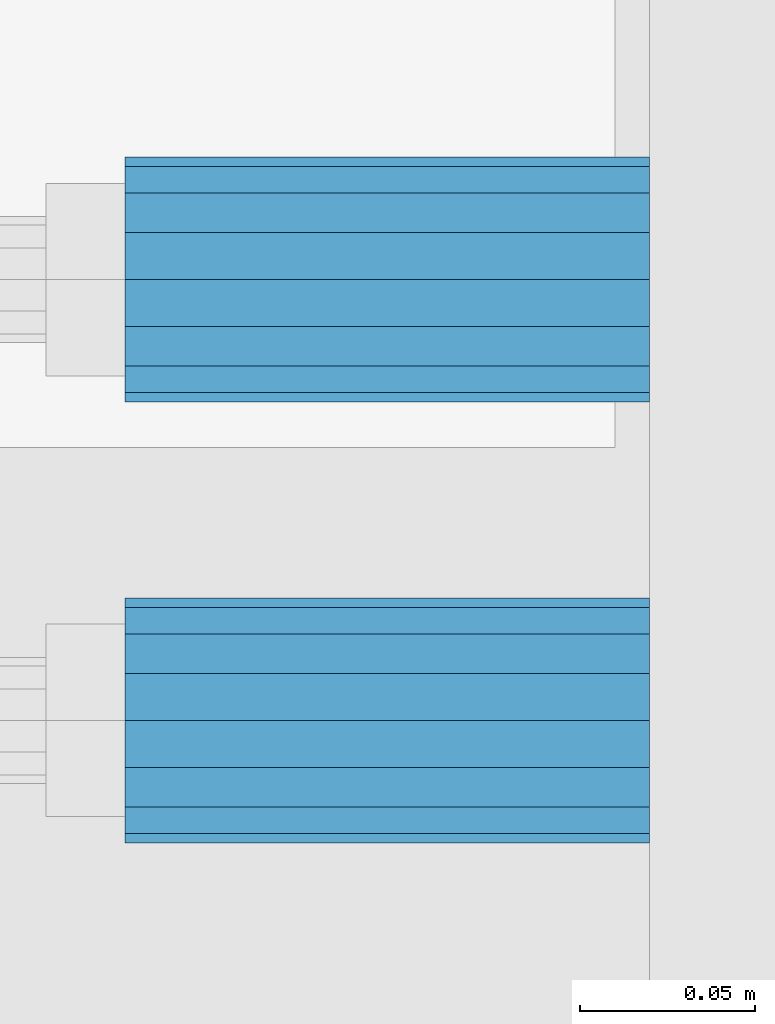
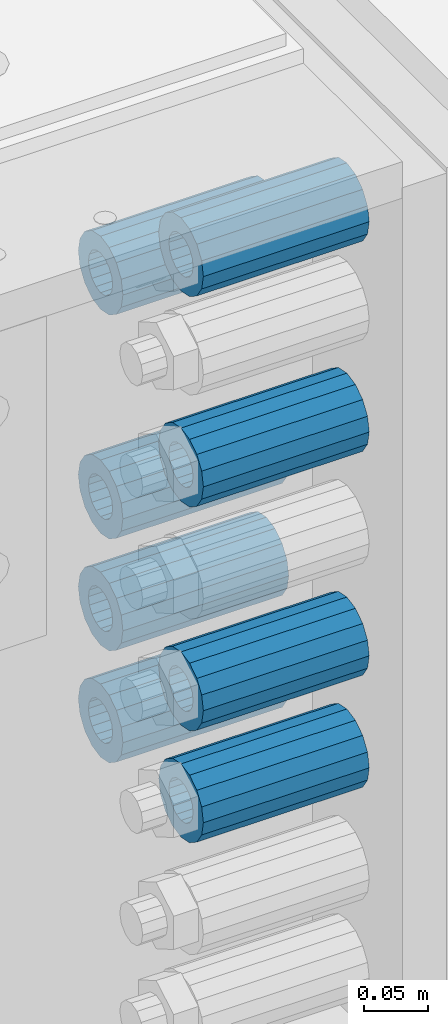
# One storey, part 157 of 242: 8 beams.
"""IFC2X3 building model written with IfcOpenShell, lengths in millimetres."""

from ifc_helpers import new_model, si_unit, frame, origin_with_axes, place, context, subcontext, project, spatial, faceted_brep, material, type_object, element, save


model = new_model("IFC2X3")

# Units and contexts
model_context = context("Model", 3, precision=1e-05, world=origin_with_axes())
body_context = subcontext(model_context, "Body", "Model", "MODEL_VIEW")
ifc_project = project(units=[si_unit("LENGTHUNIT", "METRE", prefix="MILLI"), si_unit("AREAUNIT", "SQUARE_METRE"), si_unit("VOLUMEUNIT", "CUBIC_METRE"), si_unit("MASSUNIT", "GRAM", prefix="KILO"), si_unit("TIMEUNIT", "SECOND"), si_unit("PLANEANGLEUNIT", "RADIAN"), si_unit("SOLIDANGLEUNIT", "STERADIAN"), si_unit("THERMODYNAMICTEMPERATUREUNIT", "DEGREE_CELSIUS"), si_unit("LUMINOUSINTENSITYUNIT", "LUMEN")], contexts=[model_context])

# Site, building, storey
site_placement = place(None, origin_with_axes())
site = spatial("IfcSite", under=ifc_project, at=site_placement, CompositionType="ELEMENT")
building_placement = place(site_placement, origin_with_axes())
building = spatial("IfcBuilding", under=site, at=building_placement, Name="Standard", CompositionType="ELEMENT")
storey_placement = place(building_placement, origin_with_axes())
storey = spatial("IfcBuildingStorey", under=building, at=storey_placement, Name="Undefined", CompositionType="ELEMENT", Elevation=0.0)

# Beams
ifc_material = material()
beam_type = type_object("IfcBeamType", PredefinedType="NOTDEFINED")
beam_1_placement = place(storey_placement, frame((-22210.0, -23937.0, -504.0), z_axis=(0.0, 0.0, 1.0), x_axis=(1.0, 0.0, 0.0)))
element("IfcBeam", 1, at=beam_1_placement, inside=storey, type_object=beam_type, material=ifc_material, context=body_context, shape_type="Brep", body=[
    faceted_brep([(1.33248249767348e-07, -19.0000000004493, -6.26823748461902e-09), (0.0, -17.5537111177146, 7.27098521493673), (150.0, -17.5537111177146, 7.27098521493673), (150.0, -19.0, 0.0), (0.0, -13.4350288425449, 13.4350288425444), (150.0, -13.4350288425449, 13.4350288425444), (0.0, -7.27098521493826, 17.5537111177144), (150.0, -7.27098521493826, 17.5537111177144), (-6.29370333626866e-09, -4.49290382675827e-10, 18.9999999937318), (150.0, 0.0, 19.0), (0.0, 7.27098521493826, 17.5537111177144), (150.0, 7.27098521493826, 17.5537111177144), (0.0, 13.4350288425449, 13.4350288425444), (150.0, 13.4350288425449, 13.4350288425444), (0.0, 17.5537111177146, 7.2709852149367), (150.0, 17.5537111177146, 7.2709852149367), (-1.31243723444641e-07, 18.9999999995507, -6.26823748461902e-09), (150.0, 19.0, 0.0), (0.0, 17.5537111177146, -7.2709852149367), (150.0, 17.5537111177146, -7.2709852149367), (0.0, 13.4350288425449, -13.4350288425444), (150.0, 13.4350288425449, -13.4350288425444), (0.0, 7.27098521493826, -17.5537111177144), (150.0, 7.27098521493826, -17.5537111177144), (8.2982296589762e-09, -4.49290382675827e-10, -19.0000000062719), (150.0, 0.0, -19.0), (0.0, -7.27098521493826, -17.5537111177144), (150.0, -7.27098521493826, -17.5537111177144), (0.0, -13.4350288425449, -13.4350288425444), (150.0, -13.4350288425449, -13.4350288425444), (0.0, -17.5537111177146, -7.2709852149367), (150.0, -17.5537111177146, -7.2709852149367), (-3.63797880709171e-12, -35.0, 0.0), (-3.63797880709171e-12, -32.335783637895, -13.3939201327812), (150.0, -32.3357836378964, -13.3939201327782), (150.0, -35.0, 0.0), (0.0, -24.7487373415292, -24.7487373415315), (150.0, -24.7487373415279, -24.7487373415292), (0.0, -13.3939201327782, -32.3357836378964), (150.0, -13.3939201327776, -32.335783637895), (0.0, 0.0, -35.0000000000036), (150.0, 0.0, -35.0), (0.0, 13.3939201327782, -32.3357836378964), (150.0, 13.3939201327776, -32.335783637895), (0.0, 24.7487373415292, -24.7487373415315), (150.0, 24.7487373415279, -24.7487373415292), (-3.63797880709171e-12, 32.335783637895, -13.3939201327812), (150.0, 32.3357836378964, -13.3939201327781), (-3.63797880709171e-12, 35.0, 0.0), (150.0, 35.0, 0.0), (-7.27595761418343e-12, 32.335783637895, 13.3939201327739), (150.0, 32.3357836378964, 13.3939201327781), (-7.27595761418343e-12, 24.7487373415292, 24.7487373415242), (150.0, 24.7487373415279, 24.7487373415292), (-7.27595761418343e-12, 13.3939201327781, 32.3357836378891), (150.0, 13.3939201327776, 32.335783637895), (-1.09139364212751e-11, 0.0, 34.9999999999964), (150.0, 0.0, 35.0), (-7.27595761418343e-12, -13.3939201327781, 32.3357836378891), (150.0, -13.3939201327776, 32.335783637895), (-7.27595761418343e-12, -24.7487373415292, 24.7487373415242), (150.0, -24.7487373415279, 24.7487373415292), (-7.27595761418343e-12, -32.335783637895, 13.3939201327739), (150.0, -32.3357836378964, 13.3939201327781)], [[[0, 1, 2, 3]], [[1, 4, 5, 2]], [[4, 6, 7, 5]], [[6, 8, 9, 7]], [[8, 10, 11, 9]], [[10, 12, 13, 11]], [[12, 14, 15, 13]], [[14, 16, 17, 15]], [[16, 18, 19, 17]], [[18, 20, 21, 19]], [[20, 22, 23, 21]], [[22, 24, 25, 23]], [[24, 26, 27, 25]], [[26, 28, 29, 27]], [[28, 30, 31, 29]], [[30, 0, 3, 31]], [[32, 33, 34, 35]], [[33, 36, 37, 34]], [[36, 38, 39, 37]], [[38, 40, 41, 39]], [[40, 42, 43, 41]], [[42, 44, 45, 43]], [[44, 46, 47, 45]], [[46, 48, 49, 47]], [[48, 50, 51, 49]], [[50, 52, 53, 51]], [[52, 54, 55, 53]], [[54, 56, 57, 55]], [[56, 58, 59, 57]], [[58, 60, 61, 59]], [[60, 62, 63, 61]], [[62, 32, 35, 63]], [[37, 39, 41, 43, 45, 47, 49, 51, 53, 55, 57, 59, 61, 63, 35, 34], [5, 7, 9, 11, 13, 15, 17, 19, 21, 23, 25, 27, 29, 31, 3, 2]], [[62, 60, 58, 56, 54, 52, 50, 48, 46, 44, 42, 40, 38, 36, 33, 32], [30, 28, 26, 24, 22, 20, 18, 16, 14, 12, 10, 8, 6, 4, 1, 0]]]),
])
beam_2_placement = place(storey_placement, frame((-22210.0, -23937.0, -611.0), z_axis=(0.0, 0.0, 1.0), x_axis=(1.0, 0.0, 0.0)))
element("IfcBeam", 2, at=beam_2_placement, inside=storey, type_object=beam_type, material=ifc_material, context=body_context, shape_type="Brep", body=[
    faceted_brep([(1.33248249767348e-07, -19.0000000004493, -6.26823748461902e-09), (0.0, -17.5537111177146, 7.27098521493673), (150.0, -17.5537111177146, 7.27098521493673), (150.0, -19.0, 0.0), (0.0, -13.4350288425449, 13.4350288425444), (150.0, -13.4350288425449, 13.4350288425444), (0.0, -7.27098521493826, 17.5537111177144), (150.0, -7.27098521493826, 17.5537111177144), (-6.29370333626866e-09, -4.49290382675827e-10, 18.9999999937318), (150.0, 0.0, 19.0), (0.0, 7.27098521493826, 17.5537111177144), (150.0, 7.27098521493826, 17.5537111177144), (0.0, 13.4350288425449, 13.4350288425444), (150.0, 13.4350288425449, 13.4350288425444), (0.0, 17.5537111177146, 7.2709852149367), (150.0, 17.5537111177146, 7.2709852149367), (-1.31243723444641e-07, 18.9999999995507, -6.26823748461902e-09), (150.0, 19.0, 0.0), (0.0, 17.5537111177146, -7.2709852149367), (150.0, 17.5537111177146, -7.2709852149367), (0.0, 13.4350288425449, -13.4350288425444), (150.0, 13.4350288425449, -13.4350288425444), (0.0, 7.27098521493826, -17.5537111177144), (150.0, 7.27098521493826, -17.5537111177144), (8.2982296589762e-09, -4.49290382675827e-10, -19.0000000062719), (150.0, 0.0, -19.0), (0.0, -7.27098521493826, -17.5537111177144), (150.0, -7.27098521493826, -17.5537111177144), (0.0, -13.4350288425449, -13.4350288425444), (150.0, -13.4350288425449, -13.4350288425444), (0.0, -17.5537111177146, -7.2709852149367), (150.0, -17.5537111177146, -7.2709852149367), (-3.63797880709171e-12, -35.0, 0.0), (-3.63797880709171e-12, -32.335783637895, -13.3939201327812), (150.0, -32.3357836378964, -13.3939201327782), (150.0, -35.0, 0.0), (0.0, -24.7487373415292, -24.7487373415315), (150.0, -24.7487373415279, -24.7487373415292), (0.0, -13.3939201327782, -32.3357836378964), (150.0, -13.3939201327776, -32.335783637895), (0.0, 0.0, -35.0000000000036), (150.0, 0.0, -35.0), (0.0, 13.3939201327782, -32.3357836378964), (150.0, 13.3939201327776, -32.335783637895), (0.0, 24.7487373415292, -24.7487373415315), (150.0, 24.7487373415279, -24.7487373415292), (-3.63797880709171e-12, 32.335783637895, -13.3939201327812), (150.0, 32.3357836378964, -13.3939201327781), (-3.63797880709171e-12, 35.0, 0.0), (150.0, 35.0, 0.0), (-7.27595761418343e-12, 32.335783637895, 13.3939201327739), (150.0, 32.3357836378964, 13.3939201327781), (-7.27595761418343e-12, 24.7487373415292, 24.7487373415242), (150.0, 24.7487373415279, 24.7487373415292), (-7.27595761418343e-12, 13.3939201327781, 32.3357836378891), (150.0, 13.3939201327776, 32.335783637895), (-1.09139364212751e-11, 0.0, 34.9999999999964), (150.0, 0.0, 35.0), (-7.27595761418343e-12, -13.3939201327781, 32.3357836378891), (150.0, -13.3939201327776, 32.335783637895), (-7.27595761418343e-12, -24.7487373415292, 24.7487373415242), (150.0, -24.7487373415279, 24.7487373415292), (-7.27595761418343e-12, -32.335783637895, 13.3939201327739), (150.0, -32.3357836378964, 13.3939201327781)], [[[0, 1, 2, 3]], [[1, 4, 5, 2]], [[4, 6, 7, 5]], [[6, 8, 9, 7]], [[8, 10, 11, 9]], [[10, 12, 13, 11]], [[12, 14, 15, 13]], [[14, 16, 17, 15]], [[16, 18, 19, 17]], [[18, 20, 21, 19]], [[20, 22, 23, 21]], [[22, 24, 25, 23]], [[24, 26, 27, 25]], [[26, 28, 29, 27]], [[28, 30, 31, 29]], [[30, 0, 3, 31]], [[32, 33, 34, 35]], [[33, 36, 37, 34]], [[36, 38, 39, 37]], [[38, 40, 41, 39]], [[40, 42, 43, 41]], [[42, 44, 45, 43]], [[44, 46, 47, 45]], [[46, 48, 49, 47]], [[48, 50, 51, 49]], [[50, 52, 53, 51]], [[52, 54, 55, 53]], [[54, 56, 57, 55]], [[56, 58, 59, 57]], [[58, 60, 61, 59]], [[60, 62, 63, 61]], [[62, 32, 35, 63]], [[37, 39, 41, 43, 45, 47, 49, 51, 53, 55, 57, 59, 61, 63, 35, 34], [5, 7, 9, 11, 13, 15, 17, 19, 21, 23, 25, 27, 29, 31, 3, 2]], [[62, 60, 58, 56, 54, 52, 50, 48, 46, 44, 42, 40, 38, 36, 33, 32], [30, 28, 26, 24, 22, 20, 18, 16, 14, 12, 10, 8, 6, 4, 1, 0]]]),
])
beam_3_placement = place(storey_placement, frame((-22210.0, -24063.0, -290.0), z_axis=(0.0, 0.0, 1.0), x_axis=(1.0, 0.0, 0.0)))
element("IfcBeam", 3, at=beam_3_placement, inside=storey, type_object=beam_type, material=ifc_material, context=body_context, shape_type="Brep", body=[
    faceted_brep([(1.33248249767348e-07, -19.0000000004493, -6.26823748461902e-09), (0.0, -17.5537111177146, 7.27098521493673), (150.0, -17.5537111177146, 7.27098521493673), (150.0, -19.0, 0.0), (0.0, -13.4350288425449, 13.4350288425444), (150.0, -13.4350288425449, 13.4350288425444), (0.0, -7.27098521493826, 17.5537111177144), (150.0, -7.27098521493826, 17.5537111177144), (-6.29370333626866e-09, -4.49290382675827e-10, 18.9999999937318), (150.0, 0.0, 19.0), (0.0, 7.27098521493826, 17.5537111177144), (150.0, 7.27098521493826, 17.5537111177144), (0.0, 13.4350288425449, 13.4350288425444), (150.0, 13.4350288425449, 13.4350288425444), (0.0, 17.5537111177146, 7.2709852149367), (150.0, 17.5537111177146, 7.2709852149367), (-1.31243723444641e-07, 18.9999999995507, -6.26823748461902e-09), (150.0, 19.0, 0.0), (0.0, 17.5537111177146, -7.2709852149367), (150.0, 17.5537111177146, -7.2709852149367), (0.0, 13.4350288425449, -13.4350288425444), (150.0, 13.4350288425449, -13.4350288425444), (0.0, 7.27098521493826, -17.5537111177144), (150.0, 7.27098521493826, -17.5537111177144), (8.2982296589762e-09, -4.49290382675827e-10, -19.0000000062719), (150.0, 0.0, -19.0), (0.0, -7.27098521493826, -17.5537111177144), (150.0, -7.27098521493826, -17.5537111177144), (0.0, -13.4350288425449, -13.4350288425444), (150.0, -13.4350288425449, -13.4350288425444), (0.0, -17.5537111177146, -7.2709852149367), (150.0, -17.5537111177146, -7.2709852149367), (-3.63797880709171e-12, -35.0, 0.0), (-3.63797880709171e-12, -32.335783637895, -13.3939201327812), (150.0, -32.3357836378964, -13.3939201327782), (150.0, -35.0, 0.0), (0.0, -24.7487373415292, -24.7487373415315), (150.0, -24.7487373415279, -24.7487373415292), (0.0, -13.3939201327782, -32.3357836378964), (150.0, -13.3939201327776, -32.335783637895), (0.0, 0.0, -35.0000000000036), (150.0, 0.0, -35.0), (0.0, 13.3939201327782, -32.3357836378964), (150.0, 13.3939201327776, -32.335783637895), (0.0, 24.7487373415292, -24.7487373415315), (150.0, 24.7487373415279, -24.7487373415292), (-3.63797880709171e-12, 32.335783637895, -13.3939201327812), (150.0, 32.3357836378964, -13.3939201327781), (-3.63797880709171e-12, 35.0, 0.0), (150.0, 35.0, 0.0), (-7.27595761418343e-12, 32.335783637895, 13.3939201327739), (150.0, 32.3357836378964, 13.3939201327781), (-7.27595761418343e-12, 24.7487373415292, 24.7487373415242), (150.0, 24.7487373415279, 24.7487373415292), (-7.27595761418343e-12, 13.3939201327781, 32.3357836378891), (150.0, 13.3939201327776, 32.335783637895), (-1.09139364212751e-11, 0.0, 34.9999999999964), (150.0, 0.0, 35.0), (-7.27595761418343e-12, -13.3939201327781, 32.3357836378891), (150.0, -13.3939201327776, 32.335783637895), (-7.27595761418343e-12, -24.7487373415292, 24.7487373415242), (150.0, -24.7487373415279, 24.7487373415292), (-7.27595761418343e-12, -32.335783637895, 13.3939201327739), (150.0, -32.3357836378964, 13.3939201327781)], [[[0, 1, 2, 3]], [[1, 4, 5, 2]], [[4, 6, 7, 5]], [[6, 8, 9, 7]], [[8, 10, 11, 9]], [[10, 12, 13, 11]], [[12, 14, 15, 13]], [[14, 16, 17, 15]], [[16, 18, 19, 17]], [[18, 20, 21, 19]], [[20, 22, 23, 21]], [[22, 24, 25, 23]], [[24, 26, 27, 25]], [[26, 28, 29, 27]], [[28, 30, 31, 29]], [[30, 0, 3, 31]], [[32, 33, 34, 35]], [[33, 36, 37, 34]], [[36, 38, 39, 37]], [[38, 40, 41, 39]], [[40, 42, 43, 41]], [[42, 44, 45, 43]], [[44, 46, 47, 45]], [[46, 48, 49, 47]], [[48, 50, 51, 49]], [[50, 52, 53, 51]], [[52, 54, 55, 53]], [[54, 56, 57, 55]], [[56, 58, 59, 57]], [[58, 60, 61, 59]], [[60, 62, 63, 61]], [[62, 32, 35, 63]], [[37, 39, 41, 43, 45, 47, 49, 51, 53, 55, 57, 59, 61, 63, 35, 34], [5, 7, 9, 11, 13, 15, 17, 19, 21, 23, 25, 27, 29, 31, 3, 2]], [[62, 60, 58, 56, 54, 52, 50, 48, 46, 44, 42, 40, 38, 36, 33, 32], [30, 28, 26, 24, 22, 20, 18, 16, 14, 12, 10, 8, 6, 4, 1, 0]]]),
])
beam_4_placement = place(storey_placement, frame((-22210.0, -23937.0, -183.0), z_axis=(0.0, 0.0, 1.0), x_axis=(1.0, 0.0, 0.0)))
element("IfcBeam", 4, at=beam_4_placement, inside=storey, type_object=beam_type, material=ifc_material, context=body_context, shape_type="Brep", body=[
    faceted_brep([(1.33248249767348e-07, -19.0000000004493, -6.26823748461902e-09), (0.0, -17.5537111177146, 7.27098521493673), (150.0, -17.5537111177146, 7.27098521493673), (150.0, -19.0, 0.0), (0.0, -13.4350288425449, 13.4350288425444), (150.0, -13.4350288425449, 13.4350288425444), (0.0, -7.27098521493826, 17.5537111177144), (150.0, -7.27098521493826, 17.5537111177144), (-6.29370333626866e-09, -4.49290382675827e-10, 18.9999999937318), (150.0, 0.0, 19.0), (0.0, 7.27098521493826, 17.5537111177144), (150.0, 7.27098521493826, 17.5537111177144), (0.0, 13.4350288425449, 13.4350288425444), (150.0, 13.4350288425449, 13.4350288425444), (0.0, 17.5537111177146, 7.2709852149367), (150.0, 17.5537111177146, 7.2709852149367), (-1.31243723444641e-07, 18.9999999995507, -6.26823748461902e-09), (150.0, 19.0, 0.0), (0.0, 17.5537111177146, -7.2709852149367), (150.0, 17.5537111177146, -7.2709852149367), (0.0, 13.4350288425449, -13.4350288425444), (150.0, 13.4350288425449, -13.4350288425444), (0.0, 7.27098521493826, -17.5537111177144), (150.0, 7.27098521493826, -17.5537111177144), (8.2982296589762e-09, -4.49290382675827e-10, -19.0000000062719), (150.0, 0.0, -19.0), (0.0, -7.27098521493826, -17.5537111177144), (150.0, -7.27098521493826, -17.5537111177144), (0.0, -13.4350288425449, -13.4350288425444), (150.0, -13.4350288425449, -13.4350288425444), (0.0, -17.5537111177146, -7.2709852149367), (150.0, -17.5537111177146, -7.2709852149367), (-3.63797880709171e-12, -35.0, 0.0), (-3.63797880709171e-12, -32.335783637895, -13.3939201327812), (150.0, -32.3357836378964, -13.3939201327782), (150.0, -35.0, 0.0), (0.0, -24.7487373415292, -24.7487373415315), (150.0, -24.7487373415279, -24.7487373415292), (0.0, -13.3939201327782, -32.3357836378964), (150.0, -13.3939201327776, -32.335783637895), (0.0, 0.0, -35.0000000000036), (150.0, 0.0, -35.0), (0.0, 13.3939201327782, -32.3357836378964), (150.0, 13.3939201327776, -32.335783637895), (0.0, 24.7487373415292, -24.7487373415315), (150.0, 24.7487373415279, -24.7487373415292), (-3.63797880709171e-12, 32.335783637895, -13.3939201327812), (150.0, 32.3357836378964, -13.3939201327781), (-3.63797880709171e-12, 35.0, 0.0), (150.0, 35.0, 0.0), (-7.27595761418343e-12, 32.335783637895, 13.3939201327739), (150.0, 32.3357836378964, 13.3939201327781), (-7.27595761418343e-12, 24.7487373415292, 24.7487373415242), (150.0, 24.7487373415279, 24.7487373415292), (-7.27595761418343e-12, 13.3939201327781, 32.3357836378891), (150.0, 13.3939201327776, 32.335783637895), (-1.09139364212751e-11, 0.0, 34.9999999999964), (150.0, 0.0, 35.0), (-7.27595761418343e-12, -13.3939201327781, 32.3357836378891), (150.0, -13.3939201327776, 32.335783637895), (-7.27595761418343e-12, -24.7487373415292, 24.7487373415242), (150.0, -24.7487373415279, 24.7487373415292), (-7.27595761418343e-12, -32.335783637895, 13.3939201327739), (150.0, -32.3357836378964, 13.3939201327781)], [[[0, 1, 2, 3]], [[1, 4, 5, 2]], [[4, 6, 7, 5]], [[6, 8, 9, 7]], [[8, 10, 11, 9]], [[10, 12, 13, 11]], [[12, 14, 15, 13]], [[14, 16, 17, 15]], [[16, 18, 19, 17]], [[18, 20, 21, 19]], [[20, 22, 23, 21]], [[22, 24, 25, 23]], [[24, 26, 27, 25]], [[26, 28, 29, 27]], [[28, 30, 31, 29]], [[30, 0, 3, 31]], [[32, 33, 34, 35]], [[33, 36, 37, 34]], [[36, 38, 39, 37]], [[38, 40, 41, 39]], [[40, 42, 43, 41]], [[42, 44, 45, 43]], [[44, 46, 47, 45]], [[46, 48, 49, 47]], [[48, 50, 51, 49]], [[50, 52, 53, 51]], [[52, 54, 55, 53]], [[54, 56, 57, 55]], [[56, 58, 59, 57]], [[58, 60, 61, 59]], [[60, 62, 63, 61]], [[62, 32, 35, 63]], [[37, 39, 41, 43, 45, 47, 49, 51, 53, 55, 57, 59, 61, 63, 35, 34], [5, 7, 9, 11, 13, 15, 17, 19, 21, 23, 25, 27, 29, 31, 3, 2]], [[62, 60, 58, 56, 54, 52, 50, 48, 46, 44, 42, 40, 38, 36, 33, 32], [30, 28, 26, 24, 22, 20, 18, 16, 14, 12, 10, 8, 6, 4, 1, 0]]]),
])
beam_5_placement = place(storey_placement, frame((-22210.0, -24063.0, -504.0), z_axis=(0.0, 0.0, 1.0), x_axis=(1.0, 0.0, 0.0)))
element("IfcBeam", 5, at=beam_5_placement, inside=storey, type_object=beam_type, material=ifc_material, context=body_context, shape_type="Brep", body=[
    faceted_brep([(1.33248249767348e-07, -19.0000000004493, -6.26823748461902e-09), (0.0, -17.5537111177146, 7.27098521493673), (150.0, -17.5537111177146, 7.27098521493673), (150.0, -19.0, 0.0), (0.0, -13.4350288425449, 13.4350288425444), (150.0, -13.4350288425449, 13.4350288425444), (0.0, -7.27098521493826, 17.5537111177144), (150.0, -7.27098521493826, 17.5537111177144), (-6.29370333626866e-09, -4.49290382675827e-10, 18.9999999937318), (150.0, 0.0, 19.0), (0.0, 7.27098521493826, 17.5537111177144), (150.0, 7.27098521493826, 17.5537111177144), (0.0, 13.4350288425449, 13.4350288425444), (150.0, 13.4350288425449, 13.4350288425444), (0.0, 17.5537111177146, 7.2709852149367), (150.0, 17.5537111177146, 7.2709852149367), (-1.31243723444641e-07, 18.9999999995507, -6.26823748461902e-09), (150.0, 19.0, 0.0), (0.0, 17.5537111177146, -7.2709852149367), (150.0, 17.5537111177146, -7.2709852149367), (0.0, 13.4350288425449, -13.4350288425444), (150.0, 13.4350288425449, -13.4350288425444), (0.0, 7.27098521493826, -17.5537111177144), (150.0, 7.27098521493826, -17.5537111177144), (8.2982296589762e-09, -4.49290382675827e-10, -19.0000000062719), (150.0, 0.0, -19.0), (0.0, -7.27098521493826, -17.5537111177144), (150.0, -7.27098521493826, -17.5537111177144), (0.0, -13.4350288425449, -13.4350288425444), (150.0, -13.4350288425449, -13.4350288425444), (0.0, -17.5537111177146, -7.2709852149367), (150.0, -17.5537111177146, -7.2709852149367), (-3.63797880709171e-12, -35.0, 0.0), (-3.63797880709171e-12, -32.335783637895, -13.3939201327812), (150.0, -32.3357836378964, -13.3939201327782), (150.0, -35.0, 0.0), (0.0, -24.7487373415292, -24.7487373415315), (150.0, -24.7487373415279, -24.7487373415292), (0.0, -13.3939201327782, -32.3357836378964), (150.0, -13.3939201327776, -32.335783637895), (0.0, 0.0, -35.0000000000036), (150.0, 0.0, -35.0), (0.0, 13.3939201327782, -32.3357836378964), (150.0, 13.3939201327776, -32.335783637895), (0.0, 24.7487373415292, -24.7487373415315), (150.0, 24.7487373415279, -24.7487373415292), (-3.63797880709171e-12, 32.335783637895, -13.3939201327812), (150.0, 32.3357836378964, -13.3939201327781), (-3.63797880709171e-12, 35.0, 0.0), (150.0, 35.0, 0.0), (-7.27595761418343e-12, 32.335783637895, 13.3939201327739), (150.0, 32.3357836378964, 13.3939201327781), (-7.27595761418343e-12, 24.7487373415292, 24.7487373415242), (150.0, 24.7487373415279, 24.7487373415292), (-7.27595761418343e-12, 13.3939201327781, 32.3357836378891), (150.0, 13.3939201327776, 32.335783637895), (-1.09139364212751e-11, 0.0, 34.9999999999964), (150.0, 0.0, 35.0), (-7.27595761418343e-12, -13.3939201327781, 32.3357836378891), (150.0, -13.3939201327776, 32.335783637895), (-7.27595761418343e-12, -24.7487373415292, 24.7487373415242), (150.0, -24.7487373415279, 24.7487373415292), (-7.27595761418343e-12, -32.335783637895, 13.3939201327739), (150.0, -32.3357836378964, 13.3939201327781)], [[[0, 1, 2, 3]], [[1, 4, 5, 2]], [[4, 6, 7, 5]], [[6, 8, 9, 7]], [[8, 10, 11, 9]], [[10, 12, 13, 11]], [[12, 14, 15, 13]], [[14, 16, 17, 15]], [[16, 18, 19, 17]], [[18, 20, 21, 19]], [[20, 22, 23, 21]], [[22, 24, 25, 23]], [[24, 26, 27, 25]], [[26, 28, 29, 27]], [[28, 30, 31, 29]], [[30, 0, 3, 31]], [[32, 33, 34, 35]], [[33, 36, 37, 34]], [[36, 38, 39, 37]], [[38, 40, 41, 39]], [[40, 42, 43, 41]], [[42, 44, 45, 43]], [[44, 46, 47, 45]], [[46, 48, 49, 47]], [[48, 50, 51, 49]], [[50, 52, 53, 51]], [[52, 54, 55, 53]], [[54, 56, 57, 55]], [[56, 58, 59, 57]], [[58, 60, 61, 59]], [[60, 62, 63, 61]], [[62, 32, 35, 63]], [[37, 39, 41, 43, 45, 47, 49, 51, 53, 55, 57, 59, 61, 63, 35, 34], [5, 7, 9, 11, 13, 15, 17, 19, 21, 23, 25, 27, 29, 31, 3, 2]], [[62, 60, 58, 56, 54, 52, 50, 48, 46, 44, 42, 40, 38, 36, 33, 32], [30, 28, 26, 24, 22, 20, 18, 16, 14, 12, 10, 8, 6, 4, 1, 0]]]),
])
beam_6_placement = place(storey_placement, frame((-22210.0, -24063.0, -611.0), z_axis=(0.0, 0.0, 1.0), x_axis=(1.0, 0.0, 0.0)))
element("IfcBeam", 6, at=beam_6_placement, inside=storey, type_object=beam_type, material=ifc_material, context=body_context, shape_type="Brep", body=[
    faceted_brep([(1.33248249767348e-07, -19.0000000004493, -6.26823748461902e-09), (0.0, -17.5537111177146, 7.27098521493673), (150.0, -17.5537111177146, 7.27098521493673), (150.0, -19.0, 0.0), (0.0, -13.4350288425449, 13.4350288425444), (150.0, -13.4350288425449, 13.4350288425444), (0.0, -7.27098521493826, 17.5537111177144), (150.0, -7.27098521493826, 17.5537111177144), (-6.29370333626866e-09, -4.49290382675827e-10, 18.9999999937318), (150.0, 0.0, 19.0), (0.0, 7.27098521493826, 17.5537111177144), (150.0, 7.27098521493826, 17.5537111177144), (0.0, 13.4350288425449, 13.4350288425444), (150.0, 13.4350288425449, 13.4350288425444), (0.0, 17.5537111177146, 7.2709852149367), (150.0, 17.5537111177146, 7.2709852149367), (-1.31243723444641e-07, 18.9999999995507, -6.26823748461902e-09), (150.0, 19.0, 0.0), (0.0, 17.5537111177146, -7.2709852149367), (150.0, 17.5537111177146, -7.2709852149367), (0.0, 13.4350288425449, -13.4350288425444), (150.0, 13.4350288425449, -13.4350288425444), (0.0, 7.27098521493826, -17.5537111177144), (150.0, 7.27098521493826, -17.5537111177144), (8.2982296589762e-09, -4.49290382675827e-10, -19.0000000062719), (150.0, 0.0, -19.0), (0.0, -7.27098521493826, -17.5537111177144), (150.0, -7.27098521493826, -17.5537111177144), (0.0, -13.4350288425449, -13.4350288425444), (150.0, -13.4350288425449, -13.4350288425444), (0.0, -17.5537111177146, -7.2709852149367), (150.0, -17.5537111177146, -7.2709852149367), (-3.63797880709171e-12, -35.0, 0.0), (-3.63797880709171e-12, -32.335783637895, -13.3939201327812), (150.0, -32.3357836378964, -13.3939201327782), (150.0, -35.0, 0.0), (0.0, -24.7487373415292, -24.7487373415315), (150.0, -24.7487373415279, -24.7487373415292), (0.0, -13.3939201327782, -32.3357836378964), (150.0, -13.3939201327776, -32.335783637895), (0.0, 0.0, -35.0000000000036), (150.0, 0.0, -35.0), (0.0, 13.3939201327782, -32.3357836378964), (150.0, 13.3939201327776, -32.335783637895), (0.0, 24.7487373415292, -24.7487373415315), (150.0, 24.7487373415279, -24.7487373415292), (-3.63797880709171e-12, 32.335783637895, -13.3939201327812), (150.0, 32.3357836378964, -13.3939201327781), (-3.63797880709171e-12, 35.0, 0.0), (150.0, 35.0, 0.0), (-7.27595761418343e-12, 32.335783637895, 13.3939201327739), (150.0, 32.3357836378964, 13.3939201327781), (-7.27595761418343e-12, 24.7487373415292, 24.7487373415242), (150.0, 24.7487373415279, 24.7487373415292), (-7.27595761418343e-12, 13.3939201327781, 32.3357836378891), (150.0, 13.3939201327776, 32.335783637895), (-1.09139364212751e-11, 0.0, 34.9999999999964), (150.0, 0.0, 35.0), (-7.27595761418343e-12, -13.3939201327781, 32.3357836378891), (150.0, -13.3939201327776, 32.335783637895), (-7.27595761418343e-12, -24.7487373415292, 24.7487373415242), (150.0, -24.7487373415279, 24.7487373415292), (-7.27595761418343e-12, -32.335783637895, 13.3939201327739), (150.0, -32.3357836378964, 13.3939201327781)], [[[0, 1, 2, 3]], [[1, 4, 5, 2]], [[4, 6, 7, 5]], [[6, 8, 9, 7]], [[8, 10, 11, 9]], [[10, 12, 13, 11]], [[12, 14, 15, 13]], [[14, 16, 17, 15]], [[16, 18, 19, 17]], [[18, 20, 21, 19]], [[20, 22, 23, 21]], [[22, 24, 25, 23]], [[24, 26, 27, 25]], [[26, 28, 29, 27]], [[28, 30, 31, 29]], [[30, 0, 3, 31]], [[32, 33, 34, 35]], [[33, 36, 37, 34]], [[36, 38, 39, 37]], [[38, 40, 41, 39]], [[40, 42, 43, 41]], [[42, 44, 45, 43]], [[44, 46, 47, 45]], [[46, 48, 49, 47]], [[48, 50, 51, 49]], [[50, 52, 53, 51]], [[52, 54, 55, 53]], [[54, 56, 57, 55]], [[56, 58, 59, 57]], [[58, 60, 61, 59]], [[60, 62, 63, 61]], [[62, 32, 35, 63]], [[37, 39, 41, 43, 45, 47, 49, 51, 53, 55, 57, 59, 61, 63, 35, 34], [5, 7, 9, 11, 13, 15, 17, 19, 21, 23, 25, 27, 29, 31, 3, 2]], [[62, 60, 58, 56, 54, 52, 50, 48, 46, 44, 42, 40, 38, 36, 33, 32], [30, 28, 26, 24, 22, 20, 18, 16, 14, 12, 10, 8, 6, 4, 1, 0]]]),
])
beam_7_placement = place(storey_placement, frame((-22210.0, -23937.0, -397.0), z_axis=(0.0, 0.0, 1.0), x_axis=(1.0, 0.0, 0.0)))
element("IfcBeam", 7, at=beam_7_placement, inside=storey, type_object=beam_type, material=ifc_material, context=body_context, shape_type="Brep", body=[
    faceted_brep([(1.33248249767348e-07, -19.0000000004493, -6.26823748461902e-09), (0.0, -17.5537111177146, 7.27098521493673), (150.0, -17.5537111177146, 7.27098521493673), (150.0, -19.0, 0.0), (0.0, -13.4350288425449, 13.4350288425444), (150.0, -13.4350288425449, 13.4350288425444), (0.0, -7.27098521493826, 17.5537111177144), (150.0, -7.27098521493826, 17.5537111177144), (-6.29370333626866e-09, -4.49290382675827e-10, 18.9999999937318), (150.0, 0.0, 19.0), (0.0, 7.27098521493826, 17.5537111177144), (150.0, 7.27098521493826, 17.5537111177144), (0.0, 13.4350288425449, 13.4350288425444), (150.0, 13.4350288425449, 13.4350288425444), (0.0, 17.5537111177146, 7.2709852149367), (150.0, 17.5537111177146, 7.2709852149367), (-1.31243723444641e-07, 18.9999999995507, -6.26823748461902e-09), (150.0, 19.0, 0.0), (0.0, 17.5537111177146, -7.2709852149367), (150.0, 17.5537111177146, -7.2709852149367), (0.0, 13.4350288425449, -13.4350288425444), (150.0, 13.4350288425449, -13.4350288425444), (0.0, 7.27098521493826, -17.5537111177144), (150.0, 7.27098521493826, -17.5537111177144), (8.2982296589762e-09, -4.49290382675827e-10, -19.0000000062719), (150.0, 0.0, -19.0), (0.0, -7.27098521493826, -17.5537111177144), (150.0, -7.27098521493826, -17.5537111177144), (0.0, -13.4350288425449, -13.4350288425444), (150.0, -13.4350288425449, -13.4350288425444), (0.0, -17.5537111177146, -7.2709852149367), (150.0, -17.5537111177146, -7.2709852149367), (-3.63797880709171e-12, -35.0, 0.0), (-3.63797880709171e-12, -32.335783637895, -13.3939201327812), (150.0, -32.3357836378964, -13.3939201327782), (150.0, -35.0, 0.0), (0.0, -24.7487373415292, -24.7487373415315), (150.0, -24.7487373415279, -24.7487373415292), (0.0, -13.3939201327782, -32.3357836378964), (150.0, -13.3939201327776, -32.335783637895), (0.0, 0.0, -35.0000000000036), (150.0, 0.0, -35.0), (0.0, 13.3939201327782, -32.3357836378964), (150.0, 13.3939201327776, -32.335783637895), (0.0, 24.7487373415292, -24.7487373415315), (150.0, 24.7487373415279, -24.7487373415292), (-3.63797880709171e-12, 32.335783637895, -13.3939201327812), (150.0, 32.3357836378964, -13.3939201327781), (-3.63797880709171e-12, 35.0, 0.0), (150.0, 35.0, 0.0), (-7.27595761418343e-12, 32.335783637895, 13.3939201327739), (150.0, 32.3357836378964, 13.3939201327781), (-7.27595761418343e-12, 24.7487373415292, 24.7487373415242), (150.0, 24.7487373415279, 24.7487373415292), (-7.27595761418343e-12, 13.3939201327781, 32.3357836378891), (150.0, 13.3939201327776, 32.335783637895), (-1.09139364212751e-11, 0.0, 34.9999999999964), (150.0, 0.0, 35.0), (-7.27595761418343e-12, -13.3939201327781, 32.3357836378891), (150.0, -13.3939201327776, 32.335783637895), (-7.27595761418343e-12, -24.7487373415292, 24.7487373415242), (150.0, -24.7487373415279, 24.7487373415292), (-7.27595761418343e-12, -32.335783637895, 13.3939201327739), (150.0, -32.3357836378964, 13.3939201327781)], [[[0, 1, 2, 3]], [[1, 4, 5, 2]], [[4, 6, 7, 5]], [[6, 8, 9, 7]], [[8, 10, 11, 9]], [[10, 12, 13, 11]], [[12, 14, 15, 13]], [[14, 16, 17, 15]], [[16, 18, 19, 17]], [[18, 20, 21, 19]], [[20, 22, 23, 21]], [[22, 24, 25, 23]], [[24, 26, 27, 25]], [[26, 28, 29, 27]], [[28, 30, 31, 29]], [[30, 0, 3, 31]], [[32, 33, 34, 35]], [[33, 36, 37, 34]], [[36, 38, 39, 37]], [[38, 40, 41, 39]], [[40, 42, 43, 41]], [[42, 44, 45, 43]], [[44, 46, 47, 45]], [[46, 48, 49, 47]], [[48, 50, 51, 49]], [[50, 52, 53, 51]], [[52, 54, 55, 53]], [[54, 56, 57, 55]], [[56, 58, 59, 57]], [[58, 60, 61, 59]], [[60, 62, 63, 61]], [[62, 32, 35, 63]], [[37, 39, 41, 43, 45, 47, 49, 51, 53, 55, 57, 59, 61, 63, 35, 34], [5, 7, 9, 11, 13, 15, 17, 19, 21, 23, 25, 27, 29, 31, 3, 2]], [[62, 60, 58, 56, 54, 52, 50, 48, 46, 44, 42, 40, 38, 36, 33, 32], [30, 28, 26, 24, 22, 20, 18, 16, 14, 12, 10, 8, 6, 4, 1, 0]]]),
])
beam_8_placement = place(storey_placement, frame((-22210.0, -24063.0, -89.0000000000001), z_axis=(0.0, 0.0, 1.0), x_axis=(1.0, 0.0, 0.0)))
element("IfcBeam", 8, at=beam_8_placement, inside=storey, type_object=beam_type, material=ifc_material, context=body_context, shape_type="Brep", body=[
    faceted_brep([(1.33248249767348e-07, -19.0000000004493, -6.26823748461902e-09), (0.0, -17.5537111177146, 7.27098521493673), (150.0, -17.5537111177146, 7.27098521493673), (150.0, -19.0, 0.0), (0.0, -13.4350288425449, 13.4350288425444), (150.0, -13.4350288425449, 13.4350288425444), (0.0, -7.27098521493826, 17.5537111177144), (150.0, -7.27098521493826, 17.5537111177144), (-6.29370333626866e-09, -4.49290382675827e-10, 18.9999999937318), (150.0, 0.0, 19.0), (0.0, 7.27098521493826, 17.5537111177144), (150.0, 7.27098521493826, 17.5537111177144), (0.0, 13.4350288425449, 13.4350288425444), (150.0, 13.4350288425449, 13.4350288425444), (0.0, 17.5537111177146, 7.2709852149367), (150.0, 17.5537111177146, 7.2709852149367), (-1.31243723444641e-07, 18.9999999995507, -6.26823748461902e-09), (150.0, 19.0, 0.0), (0.0, 17.5537111177146, -7.2709852149367), (150.0, 17.5537111177146, -7.2709852149367), (0.0, 13.4350288425449, -13.4350288425444), (150.0, 13.4350288425449, -13.4350288425444), (0.0, 7.27098521493826, -17.5537111177144), (150.0, 7.27098521493826, -17.5537111177144), (8.2982296589762e-09, -4.49290382675827e-10, -19.0000000062719), (150.0, 0.0, -19.0), (0.0, -7.27098521493826, -17.5537111177144), (150.0, -7.27098521493826, -17.5537111177144), (0.0, -13.4350288425449, -13.4350288425444), (150.0, -13.4350288425449, -13.4350288425444), (0.0, -17.5537111177146, -7.2709852149367), (150.0, -17.5537111177146, -7.2709852149367), (-3.63797880709171e-12, -35.0, 0.0), (-3.63797880709171e-12, -32.335783637895, -13.3939201327812), (150.0, -32.3357836378964, -13.3939201327782), (150.0, -35.0, 0.0), (0.0, -24.7487373415292, -24.7487373415315), (150.0, -24.7487373415279, -24.7487373415292), (0.0, -13.3939201327782, -32.3357836378964), (150.0, -13.3939201327776, -32.335783637895), (0.0, 0.0, -35.0000000000036), (150.0, 0.0, -35.0), (0.0, 13.3939201327782, -32.3357836378964), (150.0, 13.3939201327776, -32.335783637895), (0.0, 24.7487373415292, -24.7487373415315), (150.0, 24.7487373415279, -24.7487373415292), (-3.63797880709171e-12, 32.335783637895, -13.3939201327812), (150.0, 32.3357836378964, -13.3939201327781), (-3.63797880709171e-12, 35.0, 0.0), (150.0, 35.0, 0.0), (-7.27595761418343e-12, 32.335783637895, 13.3939201327739), (150.0, 32.3357836378964, 13.3939201327781), (-7.27595761418343e-12, 24.7487373415292, 24.7487373415242), (150.0, 24.7487373415279, 24.7487373415292), (-7.27595761418343e-12, 13.3939201327781, 32.3357836378891), (150.0, 13.3939201327776, 32.335783637895), (-1.09139364212751e-11, 0.0, 34.9999999999964), (150.0, 0.0, 35.0), (-7.27595761418343e-12, -13.3939201327781, 32.3357836378891), (150.0, -13.3939201327776, 32.335783637895), (-7.27595761418343e-12, -24.7487373415292, 24.7487373415242), (150.0, -24.7487373415279, 24.7487373415292), (-7.27595761418343e-12, -32.335783637895, 13.3939201327739), (150.0, -32.3357836378964, 13.3939201327781)], [[[0, 1, 2, 3]], [[1, 4, 5, 2]], [[4, 6, 7, 5]], [[6, 8, 9, 7]], [[8, 10, 11, 9]], [[10, 12, 13, 11]], [[12, 14, 15, 13]], [[14, 16, 17, 15]], [[16, 18, 19, 17]], [[18, 20, 21, 19]], [[20, 22, 23, 21]], [[22, 24, 25, 23]], [[24, 26, 27, 25]], [[26, 28, 29, 27]], [[28, 30, 31, 29]], [[30, 0, 3, 31]], [[32, 33, 34, 35]], [[33, 36, 37, 34]], [[36, 38, 39, 37]], [[38, 40, 41, 39]], [[40, 42, 43, 41]], [[42, 44, 45, 43]], [[44, 46, 47, 45]], [[46, 48, 49, 47]], [[48, 50, 51, 49]], [[50, 52, 53, 51]], [[52, 54, 55, 53]], [[54, 56, 57, 55]], [[56, 58, 59, 57]], [[58, 60, 61, 59]], [[60, 62, 63, 61]], [[62, 32, 35, 63]], [[37, 39, 41, 43, 45, 47, 49, 51, 53, 55, 57, 59, 61, 63, 35, 34], [5, 7, 9, 11, 13, 15, 17, 19, 21, 23, 25, 27, 29, 31, 3, 2]], [[62, 60, 58, 56, 54, 52, 50, 48, 46, 44, 42, 40, 38, 36, 33, 32], [30, 28, 26, 24, 22, 20, 18, 16, 14, 12, 10, 8, 6, 4, 1, 0]]]),
])

save(model, "model.ifc")
